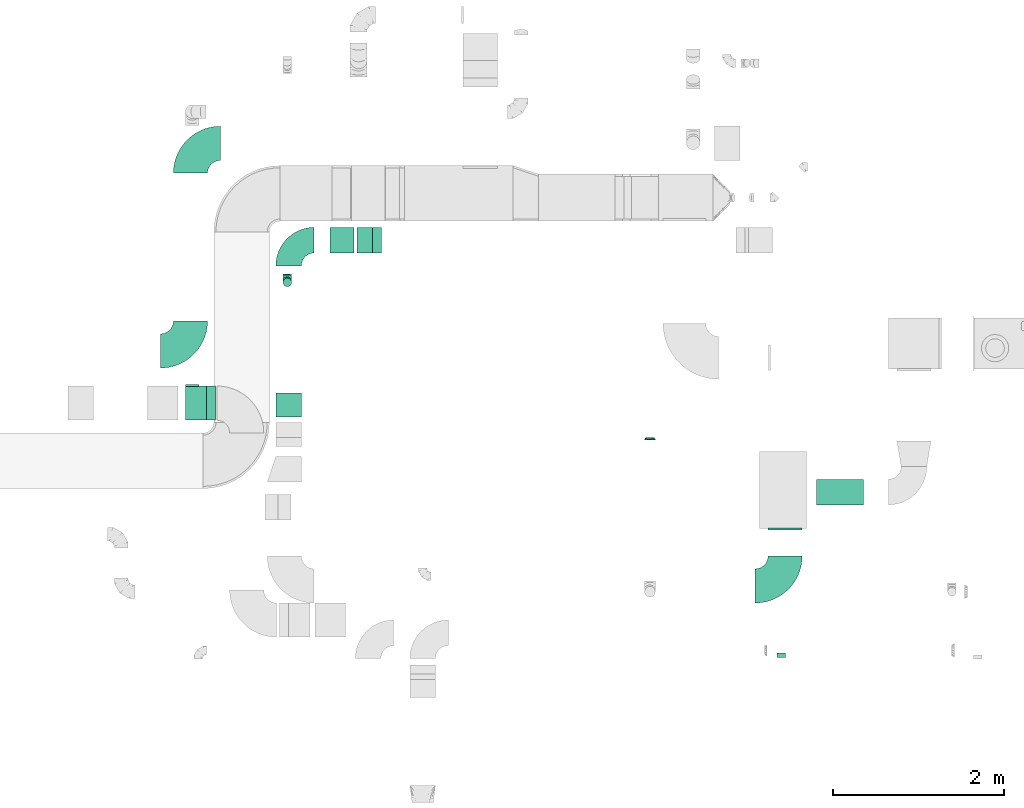
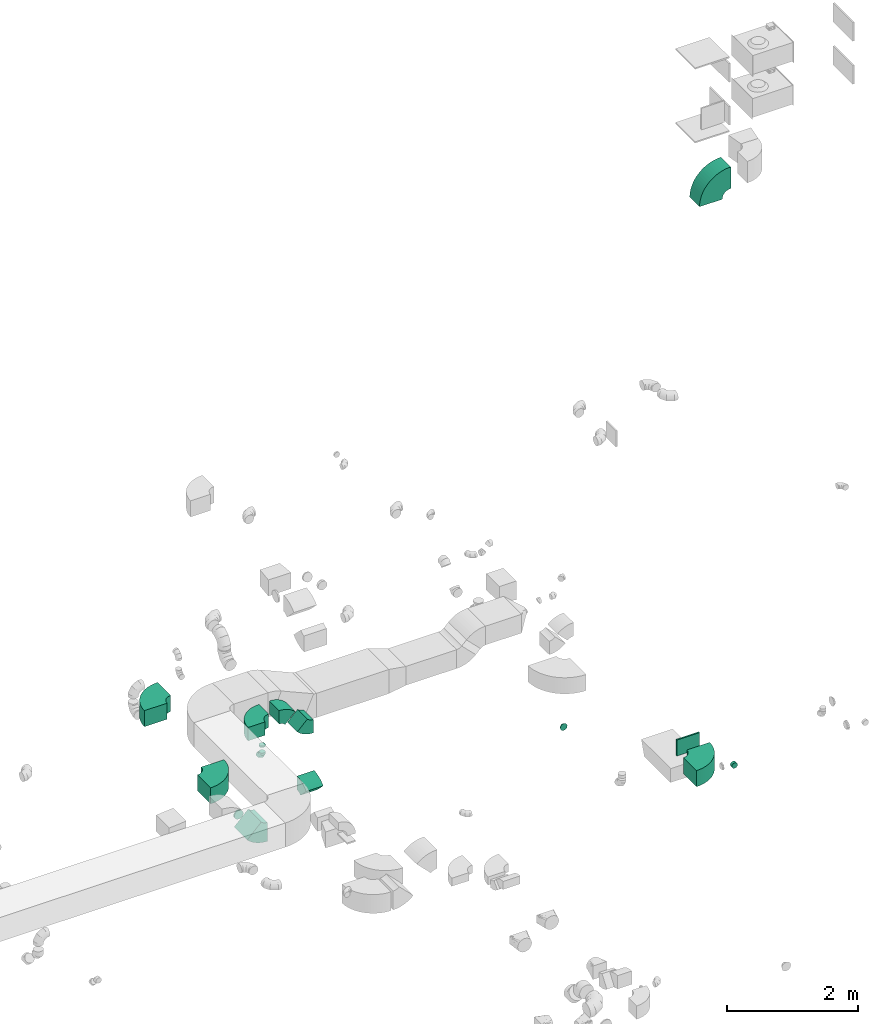
# One storey, part 12 of 44: 15 flow fittings.
"""IFC2X3 building model written with IfcOpenShell, lengths in millimetres."""

import ifcopenshell
import ifcopenshell.guid

model = None  # the IFC model being written
_history = None  # IfcOwnerHistory: only IFC2X3 demands one
_inside = {}  # id of a spatial element -> (the spatial element, [elements in it])
_under = {}  # id of a project, library or spatial element -> (it, [spatial elements below it])
_declared = {}  # id of a project -> (the project, [libraries it declares])
_typed = {}  # id of a type object -> (the type object, [elements of that type])
_made_of = {}  # id of a material, layer set ... -> (it, [elements and type objects made of it])


def new_model(schema):
    """Start an empty IFC model of exactly this schema.

    Asked for "IFC4X3", IfcOpenShell would pick the latest addendum, in which some entities
    have other attributes; the version numbers below select the first issue.
    IFC2X3 requires an IfcOwnerHistory on every rooted entity: one is made here for all.
    """
    global model, _history
    if schema == "IFC4X3":
        model = ifcopenshell.file(schema_version=(4, 3, 0, 0))
    else:
        model = ifcopenshell.file(schema=schema)
    _inside.clear()
    _under.clear()
    _declared.clear()
    _typed.clear()
    _made_of.clear()
    _history = None
    if model.schema == "IFC2X3":
        org = make("IfcOrganization", Name="unknown")
        user = make(
            "IfcPersonAndOrganization",
            ThePerson=make("IfcPerson", FamilyName="unknown"),
            TheOrganization=org,
        )
        app = make(
            "IfcApplication",
            ApplicationDeveloper=org,
            Version="unknown",
            ApplicationFullName="unknown",
            ApplicationIdentifier="unknown",
        )
        _history = make(
            "IfcOwnerHistory",
            OwningUser=user,
            OwningApplication=app,
            ChangeAction="ADDED",
            CreationDate=0,
        )
    return model


def make(cls, **values):
    """One entity of the class cls with the attributes given. An attribute that is None is left unset."""
    return model.create_entity(
        cls, **{name: value for name, value in values.items() if value is not None}
    )


def entity(cls, *values):
    """Any entity or typed value of the class cls, its attributes in the order of the schema. None: left unset."""
    e = model.create_entity(cls)
    for i, value in enumerate(values):
        if value is not None:
            e[i] = value
    return e


def rooted(cls, **values):
    """An entity with a GlobalId (a new one), such as an element, a storey or a relation."""
    return make(cls, GlobalId=ifcopenshell.guid.new(), OwnerHistory=_history, **values)


def si_unit(unit_type, name, prefix=None):
    """IfcSIUnit, for example si_unit("LENGTHUNIT", "METRE", prefix="MILLI")."""
    return make("IfcSIUnit", UnitType=unit_type, Prefix=prefix, Name=name)


def converted_unit(unit_type, name, factor, base, dimensions=None, offset=None):
    """IfcConversionBasedUnit, such as the inch: factor (a typed value) times the base unit."""
    return make(
        "IfcConversionBasedUnit"
        if offset is None
        else "IfcConversionBasedUnitWithOffset",
        ConversionOffset=offset,
        Dimensions=None
        if dimensions is None
        else entity("IfcDimensionalExponents", *dimensions),
        UnitType=unit_type,
        Name=name,
        ConversionFactor=make(
            "IfcMeasureWithUnit", ValueComponent=factor, UnitComponent=base
        ),
    )


def derived_unit(unit_type, elements):
    """IfcDerivedUnit: a product of units, each with its exponent."""
    return make(
        "IfcDerivedUnit",
        Elements=[
            make("IfcDerivedUnitElement", Unit=unit, Exponent=power)
            for unit, power in elements
        ],
        UnitType=unit_type,
    )


def assignment(units):
    """IfcUnitAssignment: the units of a project."""
    return None if units is None else make("IfcUnitAssignment", Units=units)


def point(xyz):
    """IfcCartesianPoint."""
    return None if xyz is None else make("IfcCartesianPoint", Coordinates=xyz)


def direction(xyz):
    """IfcDirection."""
    return None if xyz is None else make("IfcDirection", DirectionRatios=xyz)


def frame(location, z_axis=None, x_axis=None):
    """IfcAxis2Placement3D, a coordinate frame: its origin and axes. An axis left out is left unset."""
    return make(
        "IfcAxis2Placement3D",
        Location=point(location),
        Axis=direction(z_axis),
        RefDirection=direction(x_axis),
    )


def frame_2d(location, x_axis=None):
    """IfcAxis2Placement2D, a coordinate frame in the plane: its origin and x axis."""
    return make(
        "IfcAxis2Placement2D", Location=point(location), RefDirection=direction(x_axis)
    )


def origin():
    """The frame at (0, 0, 0) with its axes left unset."""
    return frame((0.0, 0.0, 0.0))


def origin_2d_with_axis():
    """The frame at (0, 0) in the plane with the x axis (1, 0) written out."""
    return frame_2d((0.0, 0.0), x_axis=(1.0, 0.0))


def place(relative_to, where):
    """IfcLocalPlacement: puts the frame where relative to a parent placement (None: the world)."""
    return make(
        "IfcLocalPlacement", PlacementRelTo=relative_to, RelativePlacement=where
    )


def context(
    kind, dimensions, precision=None, world=None, true_north=None, identifier=None
):
    """IfcGeometricRepresentationContext, for example the 3D "Model" context."""
    return make(
        "IfcGeometricRepresentationContext",
        ContextIdentifier=identifier,
        ContextType=kind,
        CoordinateSpaceDimension=dimensions,
        Precision=precision,
        WorldCoordinateSystem=world,
        TrueNorth=true_north,
    )


def subcontext(parent, identifier, kind, view, scale=None):
    """IfcGeometricRepresentationSubContext, for example "Body" below "Model"."""
    return make(
        "IfcGeometricRepresentationSubContext",
        ContextIdentifier=identifier,
        ContextType=kind,
        ParentContext=parent,
        TargetScale=scale,
        TargetView=view,
    )


def project(units=None, contexts=None):
    """IfcProject with its units and contexts."""
    return rooted(
        "IfcProject",
        Name="project",
        RepresentationContexts=contexts,
        UnitsInContext=assignment(units),
    )


def spatial(cls, under=None, at=None, **own):
    """A site, building, storey or space (cls), placed at a placement, below another one or the project."""
    s = rooted(cls, ObjectPlacement=at, **own)
    if under is not None:
        _under.setdefault(under.id(), (under, []))[1].append(s)
    return s


def polyline(points):
    """IfcPolyline through the points."""
    return make("IfcPolyline", Points=[point(p) for p in points])


def circle_curve(where, radius):
    """IfcCircle in the frame where."""
    return make("IfcCircle", Position=where, Radius=radius)


def parameter(value):
    """IfcParameterValue: where a trimmed curve begins or ends, as a parameter of its basis curve."""
    return model.create_entity("IfcParameterValue", value)


def trimmed(basis, trim1, trim2, sense, master):
    """IfcTrimmedCurve: the piece of a basis curve between two trims."""
    return make(
        "IfcTrimmedCurve",
        BasisCurve=basis,
        Trim1=trim1,
        Trim2=trim2,
        SenseAgreement=sense,
        MasterRepresentation=master,
    )


def segment(curve, same_sense, transition):
    """IfcCompositeCurveSegment."""
    return make(
        "IfcCompositeCurveSegment",
        Transition=transition,
        SameSense=same_sense,
        ParentCurve=curve,
    )


def composite_curve(segments, self_intersect=None):
    """IfcCompositeCurve: segments joined end to end."""
    return make("IfcCompositeCurve", Segments=segments, SelfIntersect=self_intersect)


def profile(cls, at=None, kind="AREA", **sizes):
    """A parametric profile (cls). Its sizes go by their IFC names, for example OverallWidth=200.0."""
    return make(cls, ProfileType=kind, Position=at, **sizes)


def rectangle(**sizes):
    """IfcRectangleProfileDef."""
    return profile("IfcRectangleProfileDef", **sizes)


def outline(outer, holes=None, kind="AREA"):
    """IfcArbitraryClosedProfileDef: a profile drawn as a closed curve; with holes, ...WithVoids."""
    if holes is None:
        return make("IfcArbitraryClosedProfileDef", ProfileType=kind, OuterCurve=outer)
    return make(
        "IfcArbitraryProfileDefWithVoids",
        ProfileType=kind,
        OuterCurve=outer,
        InnerCurves=holes,
    )


def extrude(swept, where, along, depth):
    """IfcExtrudedAreaSolid: the profile swept, set in the frame where, extruded along a direction by depth."""
    return make(
        "IfcExtrudedAreaSolid",
        SweptArea=swept,
        Position=where,
        ExtrudedDirection=direction(along),
        Depth=depth,
    )


def faces_of(points, faces, orient=None, outer=None):
    """IfcFace entities. A face is a list of loops; a loop is a list of indices into points, from 0.

    orient and outer hold one flag for each loop. By default every Orientation is true, the
    first loop of a face is its IfcFaceOuterBound and the others are IfcFaceBound.
    """
    made = []
    for i, loops in enumerate(faces):
        bounds = []
        for j, loop in enumerate(loops):
            is_outer = j == 0 if outer is None else outer[i][j]
            bounds.append(
                make(
                    "IfcFaceOuterBound" if is_outer else "IfcFaceBound",
                    Bound=make("IfcPolyLoop", Polygon=[points[k] for k in loop]),
                    Orientation=True if orient is None else orient[i][j],
                )
            )
        made.append(make("IfcFace", Bounds=bounds))
    return made


def faceted_brep(points, faces, orient=None, outer=None, voids=None):
    """IfcFacetedBrep: a solid bounded by flat faces; with voids (closed shells), ...WithVoids."""
    shared = [point(p) for p in points]
    hull = make("IfcClosedShell", CfsFaces=faces_of(shared, faces, orient, outer))
    if voids is None:
        return make("IfcFacetedBrep", Outer=hull)
    return make(
        "IfcFacetedBrepWithVoids",
        Outer=hull,
        Voids=[
            make(cls, CfsFaces=faces_of(shared, fs, o, b)) for cls, fs, o, b in voids
        ],
    )


def shape(context_of_items, identifier, shape_type, items):
    """IfcShapeRepresentation: the items that make up one representation, for example the "Body"."""
    return make(
        "IfcShapeRepresentation",
        ContextOfItems=context_of_items,
        RepresentationIdentifier=identifier,
        RepresentationType=shape_type,
        Items=items,
    )


def source(mapping_origin, context_of_items, identifier, shape_type, items):
    """IfcRepresentationMap: a shape defined once, which mapped items show again and again."""
    return make(
        "IfcRepresentationMap",
        MappingOrigin=mapping_origin,
        MappedRepresentation=shape(context_of_items, identifier, shape_type, items),
    )


def transform(
    local_origin,
    x_axis=None,
    y_axis=None,
    z_axis=None,
    scale=None,
    scale2=None,
    scale3=None,
    uniform=True,
):
    """IfcCartesianTransformationOperator3D, or its non-uniform kind. x_axis, y_axis, z_axis: its Axis1, 2, 3."""
    if uniform:
        return make(
            "IfcCartesianTransformationOperator3D",
            Axis1=direction(x_axis),
            Axis2=direction(y_axis),
            LocalOrigin=point(local_origin),
            Scale=scale,
            Axis3=direction(z_axis),
        )
    return make(
        "IfcCartesianTransformationOperator3DnonUniform",
        Axis1=direction(x_axis),
        Axis2=direction(y_axis),
        LocalOrigin=point(local_origin),
        Scale=scale,
        Axis3=direction(z_axis),
        Scale2=scale2,
        Scale3=scale3,
    )


def mapped(mapping_source, mapping_target):
    """IfcMappedItem: shows the shape of a source again, moved by a transform."""
    return make(
        "IfcMappedItem", MappingSource=mapping_source, MappingTarget=mapping_target
    )


def material(Name=None, Category=None):
    """IfcMaterial."""
    return make("IfcMaterial", Name=Name, Category=Category)


def made_of(thing, what):
    """Note that an element or type object is made of a material, layer set ...; save() writes the relation."""
    if what is not None:
        _made_of.setdefault(what.id(), (what, []))[1].append(thing)
    return thing


def type_object(cls, material=None, **own):
    """A type object (cls), such as IfcWallType, which elements share."""
    return made_of(rooted(cls, **own), material)


def type_shapes(of_type, sources):
    """Give a type object the sources (RepresentationMaps) that its elements show as mapped items."""
    of_type.RepresentationMaps = sources


def element(
    cls,
    number,
    at=None,
    inside=None,
    cuts=None,
    type_object=None,
    material=None,
    context=None,
    identifier="Body",
    shape_type=None,
    held_by="IfcProductDefinitionShape",
    body=None,
    shapes=None,
    **own,
):
    """One element of the class cls, such as IfcWall. Its Tag is "e" and its number.

    at: its placement. inside: the storey or other place that contains it. cuts: it is an
    opening in that element (IfcRelVoidsElement). A single representation is given by context,
    identifier, shape_type and body (its items); several are given by shapes. held_by: the class
    of the entity that holds the representations. save() writes the other relations.
    """
    e = rooted(cls, Tag="e%d" % number, ObjectPlacement=at, **own)
    if body is not None:
        shapes = [shape(context, identifier, shape_type, body)]
    if shapes is not None:
        e.Representation = make(held_by, Representations=shapes)
    if inside is not None:
        _inside.setdefault(inside.id(), (inside, []))[1].append(e)
    if cuts is not None:
        rooted(
            "IfcRelVoidsElement", RelatingBuildingElement=cuts, RelatedOpeningElement=e
        )
    if type_object is not None:
        _typed.setdefault(type_object.id(), (type_object, []))[1].append(e)
    return made_of(e, material)


def aggregate(whole, parts):
    """IfcRelAggregates: a whole, such as a stair, and the parts it consists of."""
    return rooted("IfcRelAggregates", RelatingObject=whole, RelatedObjects=parts)


def save(model, path):
    """Write the relations noted so far, then the file.

    IfcRelAggregates (storeys below a building ...), IfcRelContainedInSpatialStructure (elements
    in a storey), IfcRelDefinesByType, IfcRelAssociatesMaterial and IfcRelDeclares: one each for
    every whole, place, type object, material and project.
    """
    for whole, parts in _under.values():
        aggregate(whole, parts)
    for where, things in _inside.values():
        rooted(
            "IfcRelContainedInSpatialStructure",
            RelatedElements=things,
            RelatingStructure=where,
        )
    for kind, things in _typed.values():
        rooted("IfcRelDefinesByType", RelatedObjects=things, RelatingType=kind)
    for what, things in _made_of.values():
        rooted("IfcRelAssociatesMaterial", RelatedObjects=things, RelatingMaterial=what)
    for by, libraries in _declared.values():
        rooted("IfcRelDeclares", RelatingContext=by, RelatedDefinitions=libraries)
    model.write(path)


model = new_model("IFC2X3")

# Units and contexts
model_context = context("Model", 3, precision=0.01, world=origin(), true_north=direction((6.12303176911189e-17, 1.0)))
body_context = subcontext(model_context, "Body", "Model", "MODEL_VIEW")
ifc_project = project(units=[si_unit("LENGTHUNIT", "METRE", prefix="MILLI"), si_unit("AREAUNIT", "SQUARE_METRE"), si_unit("VOLUMEUNIT", "CUBIC_METRE"), converted_unit("PLANEANGLEUNIT", "DEGREE", entity("IfcRatioMeasure", 0.0174532925199433), si_unit("PLANEANGLEUNIT", "RADIAN"), dimensions=[0, 0, 0, 0, 0, 0, 0]), si_unit("MASSUNIT", "GRAM", prefix="KILO"), derived_unit("MASSDENSITYUNIT", [(si_unit("MASSUNIT", "GRAM", prefix="KILO"), 1), (si_unit("LENGTHUNIT", "METRE"), -3)]), derived_unit("MOMENTOFINERTIAUNIT", [(si_unit("LENGTHUNIT", "METRE"), 4)]), si_unit("TIMEUNIT", "SECOND"), si_unit("FREQUENCYUNIT", "HERTZ"), si_unit("THERMODYNAMICTEMPERATUREUNIT", "DEGREE_CELSIUS"), derived_unit("THERMALTRANSMITTANCEUNIT", [(si_unit("MASSUNIT", "GRAM", prefix="KILO"), 1), (si_unit("THERMODYNAMICTEMPERATUREUNIT", "KELVIN"), -1), (si_unit("TIMEUNIT", "SECOND"), -3)]), derived_unit("VOLUMETRICFLOWRATEUNIT", [(si_unit("LENGTHUNIT", "METRE"), 3), (si_unit("TIMEUNIT", "SECOND"), -1)]), derived_unit("MASSFLOWRATEUNIT", [(si_unit("MASSUNIT", "GRAM", prefix="KILO"), 1), (si_unit("TIMEUNIT", "SECOND"), -1)]), derived_unit("ROTATIONALFREQUENCYUNIT", [(si_unit("TIMEUNIT", "SECOND"), -1)]), si_unit("ELECTRICCURRENTUNIT", "AMPERE"), si_unit("ELECTRICVOLTAGEUNIT", "VOLT"), si_unit("POWERUNIT", "WATT"), si_unit("FORCEUNIT", "NEWTON", prefix="KILO"), si_unit("ILLUMINANCEUNIT", "LUX"), si_unit("LUMINOUSFLUXUNIT", "LUMEN"), si_unit("LUMINOUSINTENSITYUNIT", "CANDELA"), derived_unit("USERDEFINED", [(si_unit("MASSUNIT", "GRAM", prefix="KILO"), -1), (si_unit("LENGTHUNIT", "METRE"), -2), (si_unit("TIMEUNIT", "SECOND"), 3), (si_unit("LUMINOUSFLUXUNIT", "LUMEN"), 1)]), derived_unit("LINEARVELOCITYUNIT", [(si_unit("LENGTHUNIT", "METRE"), 1), (si_unit("TIMEUNIT", "SECOND"), -1)]), si_unit("PRESSUREUNIT", "PASCAL"), derived_unit("USERDEFINED", [(si_unit("LENGTHUNIT", "METRE"), -2), (si_unit("MASSUNIT", "GRAM", prefix="KILO"), 1), (si_unit("TIMEUNIT", "SECOND"), -2)]), derived_unit("LINEARFORCEUNIT", [(si_unit("MASSUNIT", "GRAM", prefix="KILO"), 1), (si_unit("LENGTHUNIT", "METRE"), 1), (si_unit("TIMEUNIT", "SECOND"), -2), (si_unit("LENGTHUNIT", "METRE"), -1)]), derived_unit("PLANARFORCEUNIT", [(si_unit("MASSUNIT", "GRAM", prefix="KILO"), 1), (si_unit("LENGTHUNIT", "METRE"), 1), (si_unit("TIMEUNIT", "SECOND"), -2), (si_unit("LENGTHUNIT", "METRE"), -2)])], contexts=[model_context])

# Site, building, storey
site_placement = place(None, origin())
site = spatial("IfcSite", under=ifc_project, at=site_placement, CompositionType="ELEMENT")
building_placement = place(site_placement, origin())
building = spatial("IfcBuilding", under=site, at=building_placement, CompositionType="ELEMENT")
storey_placement = place(building_placement, frame((0.0, 0.0, 15900.0)))
storey = spatial("IfcBuildingStorey", under=building, at=storey_placement, CompositionType="ELEMENT", Elevation=15900.0)

# Flow fittings
ifc_material = material()
duct_fitting_type_1 = type_object("IfcDuctFittingType", PredefinedType="NOTDEFINED", material=ifc_material)
shared_shape_1 = source(origin(), body_context, "Body", "SweptSolid", [
    extrude(rectangle(XDim=26.0960000000546, YDim=300.0, at=origin_2d_with_axis()), frame((6.95, 0.0, -200.0)), (0.0, 0.0, 1.0), 400.0),
])
type_shapes(duct_fitting_type_1, [shared_shape_1])
flow_fitting_1_placement = place(storey_placement, frame((24365.55, 10799.36, 2850.0), z_axis=(-1.0, 0.0, 0.0), x_axis=(0.0, -1.0, 0.0)))
element("IfcFlowFitting", 1, at=flow_fitting_1_placement, inside=storey, type_object=duct_fitting_type_1, material=ifc_material, context=body_context, shape_type="MappedRepresentation", body=[
    mapped(shared_shape_1, transform((0.0, 0.0, 0.0), scale=1.0)),
])
duct_fitting_type_2 = type_object("IfcDuctFittingType", PredefinedType="NOTDEFINED", material=ifc_material)
shared_shape_2 = source(origin(), body_context, "Body", "Brep", [
    faceted_brep([(-100.0, 0.0, -50.0), (-100.0, -12.94, -48.3), (-100.0, -25.0, -43.3), (-100.0, -35.36, -35.36), (-100.0, -43.3, -25.0), (-100.0, -48.3, -12.94), (-100.0, -50.0, 0.0), (-100.0, -48.3, 12.94), (-100.0, -43.3, 25.0), (-100.0, -35.36, 35.36), (-100.0, -25.0, 43.3), (-100.0, -12.94, 48.3), (-100.0, 0.0, 50.0), (-100.0, 12.94, 48.3), (-100.0, 25.0, 43.3), (-100.0, 35.36, 35.36), (-100.0, 43.3, 25.0), (-100.0, 48.3, 12.94), (-100.0, 50.0, 0.0), (-100.0, 48.3, -12.94), (-100.0, 43.3, -25.0), (-100.0, 35.36, -35.36), (-100.0, 25.0, -43.3), (-100.0, 12.94, -48.3), (-76.67, 12.94, 48.3), (-79.9, 25.0, 43.3), (-73.21, 0.0, 50.0), (-82.68, 35.36, 35.36), (-86.15, 48.3, 12.94), (-86.6, 50.0, 0.0), (-84.81, 43.3, 25.0), (-84.81, 43.3, -25.0), (-82.68, 35.36, -35.36), (-86.15, 48.3, -12.94), (-76.67, 12.94, -48.3), (-73.21, 0.0, -50.0), (-79.9, 25.0, -43.3), (-69.74, -12.94, -48.3), (-66.51, -25.0, -43.3), (-63.73, -35.36, -35.36), (-61.6, -43.3, -25.0), (-60.26, -48.3, -12.94), (-59.81, -50.0, 0.0), (-60.26, -48.3, 12.94), (-61.6, -43.3, 25.0), (-63.73, -35.36, 35.36), (-66.51, -25.0, 43.3), (-69.74, -12.94, 48.3), (-36.27, 36.27, 48.3), (-45.1, 45.1, 43.3), (-26.79, 26.79, 50.0), (-52.68, 52.68, 35.36), (-58.49, 58.49, 25.0), (-62.15, 62.15, 12.94), (-63.4, 63.4, 0.0), (-62.15, 62.15, -12.94), (-58.49, 58.49, -25.0), (-52.68, 52.68, -35.36), (-36.27, 36.27, -48.3), (-26.79, 26.79, -50.0), (-45.1, 45.1, -43.3), (-17.32, 17.32, -48.3), (-8.49, 8.49, -43.3), (-0.91, 0.91, -35.36), (4.9, -4.9, -25.0), (8.56, -8.56, -12.94), (9.81, -9.81, 0.0), (8.56, -8.56, 12.94), (4.9, -4.9, 25.0), (-0.91, 0.91, 35.36), (-8.49, 8.49, 43.3), (-17.32, 17.32, 48.3), (-12.94, 76.67, 48.3), (-25.0, 79.9, 43.3), (0.0, 73.21, 50.0), (-35.36, 82.68, 35.36), (-43.3, 84.81, 25.0), (-48.3, 86.15, 12.94), (-50.0, 86.6, 0.0), (-48.3, 86.15, -12.94), (-43.3, 84.81, -25.0), (-35.36, 82.68, -35.36), (-12.94, 76.67, -48.3), (0.0, 73.21, -50.0), (-25.0, 79.9, -43.3), (12.94, 69.74, -48.3), (25.0, 66.51, -43.3), (35.36, 63.73, -35.36), (43.3, 61.6, -25.0), (48.3, 60.26, -12.94), (50.0, 59.81, 0.0), (48.3, 60.26, 12.94), (43.3, 61.6, 25.0), (35.36, 63.73, 35.36), (25.0, 66.51, 43.3), (12.94, 69.74, 48.3), (-12.94, 100.0, -48.3), (-25.0, 100.0, -43.3), (-35.36, 100.0, -35.36), (-43.3, 100.0, -25.0), (-48.3, 100.0, -12.94), (-50.0, 100.0, 0.0), (-48.3, 100.0, 12.94), (-43.3, 100.0, 25.0), (-35.36, 100.0, 35.36), (-25.0, 100.0, 43.3), (-12.94, 100.0, 48.3), (0.0, 100.0, 50.0), (12.94, 100.0, 48.3), (25.0, 100.0, 43.3), (35.36, 100.0, 35.36), (43.3, 100.0, 25.0), (48.3, 100.0, 12.94), (50.0, 100.0, 0.0), (48.3, 100.0, -12.94), (43.3, 100.0, -25.0), (35.36, 100.0, -35.36), (25.0, 100.0, -43.3), (12.94, 100.0, -48.3), (0.0, 100.0, -50.0)], [[[0, 1, 2, 3, 4, 5, 6, 7, 8, 9, 10, 11, 12, 13, 14, 15, 16, 17, 18, 19, 20, 21, 22, 23]], [[24, 25, 14, 13]], [[26, 24, 13, 12]], [[14, 25, 27, 15]], [[28, 29, 18, 17]], [[30, 28, 17, 16]], [[15, 27, 30, 16]], [[20, 31, 32, 21]], [[33, 31, 20, 19]], [[18, 29, 33, 19]], [[34, 35, 0, 23]], [[36, 34, 23, 22]], [[32, 36, 22, 21]], [[2, 1, 37, 38]], [[3, 2, 38, 39]], [[0, 35, 37, 1]], [[5, 4, 40, 41]], [[6, 5, 41, 42]], [[3, 39, 40, 4]], [[6, 42, 43, 7]], [[7, 43, 44, 8]], [[8, 44, 45, 9]], [[10, 46, 47, 11]], [[11, 47, 26, 12]], [[10, 9, 45, 46]], [[48, 49, 25, 24]], [[50, 48, 24, 26]], [[27, 25, 49, 51]], [[52, 53, 28, 30]], [[51, 52, 30, 27]], [[29, 28, 53, 54]], [[55, 56, 31, 33]], [[54, 55, 33, 29]], [[57, 32, 31, 56]], [[58, 59, 35, 34]], [[60, 58, 34, 36]], [[57, 60, 36, 32]], [[37, 35, 59, 61]], [[38, 37, 61, 62]], [[39, 38, 62, 63]], [[41, 40, 64, 65]], [[42, 41, 65, 66]], [[63, 64, 40, 39]], [[43, 42, 66, 67]], [[44, 43, 67, 68]], [[68, 69, 45, 44]], [[46, 45, 69, 70]], [[47, 46, 70, 71]], [[26, 47, 71, 50]], [[72, 73, 49, 48]], [[74, 72, 48, 50]], [[51, 49, 73, 75]], [[76, 77, 53, 52]], [[75, 76, 52, 51]], [[54, 53, 77, 78]], [[79, 80, 56, 55]], [[78, 79, 55, 54]], [[81, 57, 56, 80]], [[82, 83, 59, 58]], [[84, 82, 58, 60]], [[81, 84, 60, 57]], [[61, 59, 83, 85]], [[62, 61, 85, 86]], [[63, 62, 86, 87]], [[65, 64, 88, 89]], [[66, 65, 89, 90]], [[87, 88, 64, 63]], [[67, 66, 90, 91]], [[68, 67, 91, 92]], [[92, 93, 69, 68]], [[70, 69, 93, 94]], [[71, 70, 94, 95]], [[50, 71, 95, 74]], [[96, 97, 98, 99, 100, 101, 102, 103, 104, 105, 106, 107, 108, 109, 110, 111, 112, 113, 114, 115, 116, 117, 118, 119]], [[72, 74, 107, 106]], [[73, 72, 106, 105]], [[75, 73, 105, 104]], [[77, 76, 103, 102]], [[78, 77, 102, 101]], [[75, 104, 103, 76]], [[78, 101, 100, 79]], [[79, 100, 99, 80]], [[80, 99, 98, 81]], [[96, 119, 83, 82]], [[97, 96, 82, 84]], [[84, 81, 98, 97]], [[83, 119, 118, 85]], [[85, 118, 117, 86]], [[86, 117, 116, 87]], [[88, 115, 114, 89]], [[89, 114, 113, 90]], [[87, 116, 115, 88]], [[91, 90, 113, 112]], [[92, 91, 112, 111]], [[93, 92, 111, 110]], [[95, 94, 109, 108]], [[74, 95, 108, 107]], [[110, 109, 94, 93]]]),
])
type_shapes(duct_fitting_type_2, [shared_shape_2])
flow_fitting_2_placement = place(storey_placement, frame((18534.53, 13681.21, 2900.0), z_axis=(-1.0, 0.0, 0.0), x_axis=(0.0, -1.0, 0.0)))
element("IfcFlowFitting", 2, at=flow_fitting_2_placement, inside=storey, type_object=duct_fitting_type_2, material=ifc_material, context=body_context, shape_type="MappedRepresentation", body=[
    mapped(shared_shape_2, transform((0.0, 0.0, 0.0), scale=1.0)),
])
duct_fitting_type_3 = type_object("IfcDuctFittingType", PredefinedType="NOTDEFINED", material=ifc_material)
shared_shape_3 = source(origin(), body_context, "Body", "Brep", [
    faceted_brep([(20.0, 0.0, -80.0), (20.0, 20.71, -77.27), (20.0, 40.0, -69.28), (20.0, 56.57, -56.57), (20.0, 69.28, -40.0), (20.0, 77.27, -20.71), (20.0, 80.0, 0.0), (20.0, 77.27, 20.71), (20.0, 69.28, 40.0), (20.0, 56.57, 56.57), (20.0, 40.0, 69.28), (20.0, 20.71, 77.27), (20.0, 0.0, 80.0), (20.0, -20.71, 77.27), (20.0, -40.0, 69.28), (20.0, -56.57, 56.57), (20.0, -69.28, 40.0), (20.0, -77.27, 20.71), (20.0, -80.0, 0.0), (20.0, -77.27, -20.71), (20.0, -69.28, -40.0), (20.0, -56.57, -56.57), (20.0, -40.0, -69.28), (20.0, -20.71, -77.27), (0.0, 0.0, 80.0), (-6.1, 0.0, 80.0), (-6.1, -20.71, 77.27), (0.0, -20.71, 77.27), (-6.1, -40.0, 69.28), (0.0, -40.0, 69.28), (0.0, -56.57, 56.57), (-6.1, -56.57, 56.57), (0.0, -69.28, 40.0), (-6.1, -69.28, 40.0), (-6.1, -77.27, 20.71), (0.0, -77.27, 20.71), (-6.1, -80.0, 0.0), (0.0, -80.0, 0.0), (-6.1, -77.27, -20.71), (0.0, -77.27, -20.71), (-6.1, -69.28, -40.0), (0.0, -69.28, -40.0), (0.0, -56.57, -56.57), (-6.1, -56.57, -56.57), (0.0, -40.0, -69.28), (-6.1, -40.0, -69.28), (-6.1, -20.71, -77.27), (0.0, -20.71, -77.27), (-6.1, 0.0, -80.0), (0.0, 0.0, -80.0), (-6.1, 20.71, -77.27), (0.0, 20.71, -77.27), (-6.1, 40.0, -69.28), (0.0, 40.0, -69.28), (0.0, 56.57, -56.57), (-6.1, 56.57, -56.57), (0.0, 69.28, -40.0), (-6.1, 69.28, -40.0), (-6.1, 77.27, -20.71), (0.0, 77.27, -20.71), (-6.1, 80.0, 0.0), (0.0, 80.0, 0.0), (-6.1, 77.27, 20.71), (0.0, 77.27, 20.71), (-6.1, 69.28, 40.0), (0.0, 69.28, 40.0), (0.0, 56.57, 56.57), (-6.1, 56.57, 56.57), (0.0, 40.0, 69.28), (-6.1, 40.0, 69.28), (-6.1, 20.71, 77.27), (0.0, 20.71, 77.27)], [[[0, 1, 2, 3, 4, 5, 6, 7, 8, 9, 10, 11, 12, 13, 14, 15, 16, 17, 18, 19, 20, 21, 22, 23]], [[13, 12, 24, 25, 26, 27]], [[14, 13, 27, 26, 28, 29]], [[30, 15, 14, 29, 28, 31]], [[17, 16, 32, 33, 34, 35]], [[18, 17, 35, 34, 36, 37]], [[32, 16, 15, 30, 31, 33]], [[19, 18, 37, 36, 38, 39]], [[20, 19, 39, 38, 40, 41]], [[42, 21, 20, 41, 40, 43]], [[23, 22, 44, 45, 46, 47]], [[0, 23, 47, 46, 48, 49]], [[44, 22, 21, 42, 43, 45]], [[1, 0, 49, 48, 50, 51]], [[2, 1, 51, 50, 52, 53]], [[54, 3, 2, 53, 52, 55]], [[5, 4, 56, 57, 58, 59]], [[6, 5, 59, 58, 60, 61]], [[56, 4, 3, 54, 55, 57]], [[7, 6, 61, 60, 62, 63]], [[8, 7, 63, 62, 64, 65]], [[66, 9, 8, 65, 64, 67]], [[11, 10, 68, 69, 70, 71]], [[12, 11, 71, 70, 25, 24]], [[68, 10, 9, 66, 67, 69]], [[46, 45, 43, 40, 38, 36, 34, 33, 31, 28, 26, 25, 70, 69, 67, 64, 62, 60, 58, 57, 55, 52, 50, 48]]]),
])
type_shapes(duct_fitting_type_3, [shared_shape_3])
flow_fitting_3_placement = place(storey_placement, frame((17420.49, 12467.41, 2950.0), z_axis=(0.0, 0.0, -1.0), x_axis=(0.0, 1.0, 0.0)))
element("IfcFlowFitting", 3, at=flow_fitting_3_placement, inside=storey, type_object=duct_fitting_type_3, material=ifc_material, context=body_context, shape_type="MappedRepresentation", body=[
    mapped(shared_shape_3, transform((0.0, 0.0, 0.0), scale=1.0)),
])
duct_fitting_type_4 = type_object("IfcDuctFittingType", PredefinedType="NOTDEFINED", material=ifc_material)
shared_shape_4 = source(origin(), body_context, "Body", "Brep", [
    faceted_brep([(25.0, -46.19, 19.13), (25.0, -48.1, 9.57), (25.0, -50.0, 0.0), (25.0, -48.1, -9.57), (25.0, -46.19, -19.13), (25.0, -40.77, -27.24), (25.0, -35.36, -35.36), (25.0, -27.24, -40.77), (25.0, -19.13, -46.19), (25.0, -9.57, -48.1), (25.0, 0.0, -50.0), (25.0, 9.57, -48.1), (25.0, 19.13, -46.19), (25.0, 27.24, -40.77), (25.0, 35.36, -35.36), (25.0, 40.77, -27.24), (25.0, 46.19, -19.13), (25.0, 48.1, -9.57), (25.0, 50.0, 0.0), (25.0, 48.1, 9.57), (25.0, 46.19, 19.13), (25.0, 40.77, 27.24), (25.0, 35.36, 35.36), (25.0, 27.24, 40.77), (25.0, 19.13, 46.19), (25.0, 9.57, 48.1), (25.0, 0.0, 50.0), (25.0, -9.57, 48.1), (25.0, -19.13, 46.19), (25.0, -27.24, 40.77), (25.0, -35.36, 35.36), (25.0, -40.77, 27.24), (0.0, -62.5, 0.0), (0.0, -60.02, 12.45), (0.0, -57.74, 23.92), (0.0, -50.97, 34.06), (0.0, -44.19, 44.19), (0.0, -34.06, 50.97), (0.0, -23.92, 57.74), (0.0, -12.45, 60.02), (0.0, 0.0, 62.5), (0.0, 12.45, 60.02), (0.0, 23.92, 57.74), (0.0, 34.06, 50.97), (0.0, 44.19, 44.19), (0.0, 50.97, 34.06), (0.0, 57.74, 23.92), (0.0, 60.02, 12.45), (0.0, 62.5, 0.0), (0.0, 60.02, -12.45), (0.0, 57.74, -23.92), (0.0, 50.97, -34.06), (0.0, 44.19, -44.19), (0.0, 34.06, -50.97), (0.0, 23.92, -57.74), (0.0, 12.45, -60.02), (0.0, 0.0, -62.5), (0.0, -12.45, -60.02), (0.0, -23.92, -57.74), (0.0, -34.06, -50.97), (0.0, -44.19, -44.19), (0.0, -50.97, -34.06), (0.0, -57.74, -23.92), (0.0, -60.02, -12.45)], [[[0, 1, 2, 3, 4, 5, 6, 7, 8, 9, 10, 11, 12, 13, 14, 15, 16, 17, 18, 19, 20, 21, 22, 23, 24, 25, 26, 27, 28, 29, 30, 31]], [[32, 33, 34, 35, 36, 37, 38, 39, 40, 41, 42, 43, 44, 45, 46, 47, 48, 49, 50, 51, 52, 53, 54, 55, 56, 57, 58, 59, 60, 61, 62, 63]], [[24, 42, 41, 40, 26, 25]], [[22, 44, 43, 42, 24, 23]], [[48, 47, 46, 20, 19, 18]], [[44, 22, 21, 20, 46, 45]], [[0, 34, 33, 32, 2, 1]], [[30, 36, 35, 34, 0, 31]], [[40, 39, 38, 28, 27, 26]], [[36, 30, 29, 28, 38, 37]], [[8, 58, 57, 56, 10, 9]], [[6, 60, 59, 58, 8, 7]], [[32, 63, 62, 4, 3, 2]], [[60, 6, 5, 4, 62, 61]], [[16, 50, 49, 48, 18, 17]], [[14, 52, 51, 50, 16, 15]], [[56, 55, 54, 12, 11, 10]], [[52, 14, 13, 12, 54, 53]]]),
])
type_shapes(duct_fitting_type_4, [shared_shape_4])
flow_fitting_4_placement = place(storey_placement, frame((22782.58, 11837.12, 3085.0), z_axis=(0.0, 0.0, 1.0), x_axis=(0.0, 1.0, 0.0)))
element("IfcFlowFitting", 4, at=flow_fitting_4_placement, inside=storey, type_object=duct_fitting_type_4, material=ifc_material, context=body_context, shape_type="MappedRepresentation", body=[
    mapped(shared_shape_4, transform((0.0, 0.0, 0.0), scale=1.0)),
])
duct_fitting_type_5 = type_object("IfcDuctFittingType", PredefinedType="NOTDEFINED", material=ifc_material)
shared_shape_5 = source(origin(), body_context, "Body", "Brep", [
    faceted_brep([(20.0, 0.0, -50.0), (20.0, 12.94, -48.3), (20.0, 25.0, -43.3), (20.0, 35.36, -35.36), (20.0, 43.3, -25.0), (20.0, 48.3, -12.94), (20.0, 50.0, 0.0), (20.0, 48.3, 12.94), (20.0, 43.3, 25.0), (20.0, 35.36, 35.36), (20.0, 25.0, 43.3), (20.0, 12.94, 48.3), (20.0, 0.0, 50.0), (20.0, -12.94, 48.3), (20.0, -25.0, 43.3), (20.0, -35.36, 35.36), (20.0, -43.3, 25.0), (20.0, -48.3, 12.94), (20.0, -50.0, 0.0), (20.0, -48.3, -12.94), (20.0, -43.3, -25.0), (20.0, -35.36, -35.36), (20.0, -25.0, -43.3), (20.0, -12.94, -48.3), (0.0, 0.0, 50.0), (-6.1, 0.0, 50.0), (-6.1, -12.94, 48.3), (0.0, -12.94, 48.3), (-6.1, -25.0, 43.3), (0.0, -25.0, 43.3), (0.0, -35.36, 35.36), (-6.1, -35.36, 35.36), (0.0, -43.3, 25.0), (-6.1, -43.3, 25.0), (-6.1, -48.3, 12.94), (0.0, -48.3, 12.94), (-6.1, -50.0, 0.0), (0.0, -50.0, 0.0), (-6.1, -48.3, -12.94), (0.0, -48.3, -12.94), (-6.1, -43.3, -25.0), (0.0, -43.3, -25.0), (0.0, -35.36, -35.36), (-6.1, -35.36, -35.36), (0.0, -25.0, -43.3), (-6.1, -25.0, -43.3), (-6.1, -12.94, -48.3), (0.0, -12.94, -48.3), (-6.1, 0.0, -50.0), (0.0, 0.0, -50.0), (-6.1, 12.94, -48.3), (0.0, 12.94, -48.3), (-6.1, 25.0, -43.3), (0.0, 25.0, -43.3), (0.0, 35.36, -35.36), (-6.1, 35.36, -35.36), (0.0, 43.3, -25.0), (-6.1, 43.3, -25.0), (-6.1, 48.3, -12.94), (0.0, 48.3, -12.94), (-6.1, 50.0, 0.0), (0.0, 50.0, 0.0), (-6.1, 48.3, 12.94), (0.0, 48.3, 12.94), (-6.1, 43.3, 25.0), (0.0, 43.3, 25.0), (0.0, 35.36, 35.36), (-6.1, 35.36, 35.36), (0.0, 25.0, 43.3), (-6.1, 25.0, 43.3), (-6.1, 12.94, 48.3), (0.0, 12.94, 48.3)], [[[0, 1, 2, 3, 4, 5, 6, 7, 8, 9, 10, 11, 12, 13, 14, 15, 16, 17, 18, 19, 20, 21, 22, 23]], [[13, 12, 24, 25, 26, 27]], [[14, 13, 27, 26, 28, 29]], [[30, 15, 14, 29, 28, 31]], [[17, 16, 32, 33, 34, 35]], [[18, 17, 35, 34, 36, 37]], [[32, 16, 15, 30, 31, 33]], [[19, 18, 37, 36, 38, 39]], [[20, 19, 39, 38, 40, 41]], [[42, 21, 20, 41, 40, 43]], [[23, 22, 44, 45, 46, 47]], [[0, 23, 47, 46, 48, 49]], [[44, 22, 21, 42, 43, 45]], [[1, 0, 49, 48, 50, 51]], [[2, 1, 51, 50, 52, 53]], [[54, 3, 2, 53, 52, 55]], [[5, 4, 56, 57, 58, 59]], [[6, 5, 59, 58, 60, 61]], [[56, 4, 3, 54, 55, 57]], [[7, 6, 61, 60, 62, 63]], [[8, 7, 63, 62, 64, 65]], [[66, 9, 8, 65, 64, 67]], [[11, 10, 68, 69, 70, 71]], [[12, 11, 71, 70, 25, 24]], [[68, 10, 9, 66, 67, 69]], [[46, 45, 43, 40, 38, 36, 34, 33, 31, 28, 26, 25, 70, 69, 67, 64, 62, 60, 58, 57, 55, 52, 50, 48]]]),
])
type_shapes(duct_fitting_type_5, [shared_shape_5])
flow_fitting_5_placement = place(storey_placement, frame((18534.53, 13681.21, 3125.0), z_axis=(0.0, 1.0, 0.0), x_axis=(0.0, 0.0, -1.0)))
element("IfcFlowFitting", 5, at=flow_fitting_5_placement, inside=storey, type_object=duct_fitting_type_5, material=ifc_material, context=body_context, shape_type="MappedRepresentation", body=[
    mapped(shared_shape_5, transform((0.0, 0.0, 0.0), scale=1.0)),
])
duct_fitting_type_6 = type_object("IfcDuctFittingType", PredefinedType="NOTDEFINED", material=ifc_material)
shared_shape_6 = source(origin(), body_context, "Body", "Brep", [
    faceted_brep([(20.0, 0.0, -50.0), (20.0, 12.94, -48.3), (20.0, 25.0, -43.3), (20.0, 35.36, -35.36), (20.0, 43.3, -25.0), (20.0, 48.3, -12.94), (20.0, 50.0, 0.0), (20.0, 48.3, 12.94), (20.0, 43.3, 25.0), (20.0, 35.36, 35.36), (20.0, 25.0, 43.3), (20.0, 12.94, 48.3), (20.0, 0.0, 50.0), (20.0, -12.94, 48.3), (20.0, -25.0, 43.3), (20.0, -35.36, 35.36), (20.0, -43.3, 25.0), (20.0, -48.3, 12.94), (20.0, -50.0, 0.0), (20.0, -48.3, -12.94), (20.0, -43.3, -25.0), (20.0, -35.36, -35.36), (20.0, -25.0, -43.3), (20.0, -12.94, -48.3), (0.0, 0.0, 50.0), (-31.1, 0.0, 50.0), (-31.1, -12.94, 48.3), (0.0, -12.94, 48.3), (-31.1, -25.0, 43.3), (0.0, -25.0, 43.3), (0.0, -35.36, 35.36), (-31.1, -35.36, 35.36), (0.0, -43.3, 25.0), (-31.1, -43.3, 25.0), (-31.1, -48.3, 12.94), (0.0, -48.3, 12.94), (-31.1, -50.0, 0.0), (0.0, -50.0, 0.0), (-31.1, -48.3, -12.94), (0.0, -48.3, -12.94), (-31.1, -43.3, -25.0), (0.0, -43.3, -25.0), (0.0, -35.36, -35.36), (-31.1, -35.36, -35.36), (0.0, -25.0, -43.3), (-31.1, -25.0, -43.3), (-31.1, -12.94, -48.3), (0.0, -12.94, -48.3), (-31.1, 0.0, -50.0), (0.0, 0.0, -50.0), (-31.1, 12.94, -48.3), (0.0, 12.94, -48.3), (-31.1, 25.0, -43.3), (0.0, 25.0, -43.3), (0.0, 35.36, -35.36), (-31.1, 35.36, -35.36), (0.0, 43.3, -25.0), (-31.1, 43.3, -25.0), (-31.1, 48.3, -12.94), (0.0, 48.3, -12.94), (-31.1, 50.0, 0.0), (0.0, 50.0, 0.0), (-31.1, 48.3, 12.94), (0.0, 48.3, 12.94), (-31.1, 43.3, 25.0), (0.0, 43.3, 25.0), (0.0, 35.36, 35.36), (-31.1, 35.36, 35.36), (0.0, 25.0, 43.3), (-31.1, 25.0, 43.3), (-31.1, 12.94, 48.3), (0.0, 12.94, 48.3)], [[[0, 1, 2, 3, 4, 5, 6, 7, 8, 9, 10, 11, 12, 13, 14, 15, 16, 17, 18, 19, 20, 21, 22, 23]], [[13, 12, 24, 25, 26, 27]], [[14, 13, 27, 26, 28, 29]], [[30, 15, 14, 29, 28, 31]], [[17, 16, 32, 33, 34, 35]], [[18, 17, 35, 34, 36, 37]], [[32, 16, 15, 30, 31, 33]], [[19, 18, 37, 36, 38, 39]], [[20, 19, 39, 38, 40, 41]], [[42, 21, 20, 41, 40, 43]], [[23, 22, 44, 45, 46, 47]], [[0, 23, 47, 46, 48, 49]], [[44, 22, 21, 42, 43, 45]], [[1, 0, 49, 48, 50, 51]], [[2, 1, 51, 50, 52, 53]], [[54, 3, 2, 53, 52, 55]], [[5, 4, 56, 57, 58, 59]], [[6, 5, 59, 58, 60, 61]], [[56, 4, 3, 54, 55, 57]], [[7, 6, 61, 60, 62, 63]], [[8, 7, 63, 62, 64, 65]], [[66, 9, 8, 65, 64, 67]], [[11, 10, 68, 69, 70, 71]], [[12, 11, 71, 70, 25, 24]], [[68, 10, 9, 66, 67, 69]], [[46, 45, 43, 40, 38, 36, 34, 33, 31, 28, 26, 25, 70, 69, 67, 64, 62, 60, 58, 57, 55, 52, 50, 48]]]),
])
type_shapes(duct_fitting_type_6, [shared_shape_6])
flow_fitting_6_placement = place(storey_placement, frame((24320.86, 9307.62, 3375.0), z_axis=(0.0, 0.0, -1.0), x_axis=(0.0, -1.0, 0.0)))
element("IfcFlowFitting", 6, at=flow_fitting_6_placement, inside=storey, type_object=duct_fitting_type_6, material=ifc_material, context=body_context, shape_type="MappedRepresentation", body=[
    mapped(shared_shape_6, transform((0.0, 0.0, 0.0), scale=1.0)),
])
duct_fitting_type_7 = type_object("IfcDuctFittingType", PredefinedType="NOTDEFINED", material=ifc_material)
shared_shape_7 = source(origin(), body_context, "Body", "SweptSolid", [
    extrude(outline(composite_curve([segment(polyline([(-300.0, -150.0), (0.0, -150.0)]), True, "CONTINUOUS"), segment(trimmed(circle_curve(frame_2d((150.0, -150.0), x_axis=(0.0, 1.0)), 150.0), [parameter(0.0)], [parameter(90.0)], True, "PARAMETER"), False, "CONTINUOUS"), segment(polyline([(150.0, 0.0), (150.0, 300.0)]), True, "CONTINUOUS"), segment(trimmed(circle_curve(frame_2d((150.0, -150.0), x_axis=(0.0, 1.0)), 450.0), [parameter(0.0)], [parameter(90.0000000000001)], True, "PARAMETER"), True, "CONTINUOUS")], self_intersect=False)), frame((-150.0, 150.0, -125.0), z_axis=(0.0, 0.0, 1.0), x_axis=(-1.0, 0.0, 0.0)), (0.0, 0.0, 1.0), 250.0),
])
type_shapes(duct_fitting_type_7, [shared_shape_7])
flow_fitting_7_placement = place(storey_placement, frame((18549.92, 14175.53, 3250.0), z_axis=(0.0, 0.0, 1.0), x_axis=(-1.0, 0.0, 0.0)))
element("IfcFlowFitting", 7, at=flow_fitting_7_placement, inside=storey, type_object=duct_fitting_type_7, material=ifc_material, context=body_context, shape_type="MappedRepresentation", body=[
    mapped(shared_shape_7, transform((0.0, 0.0, 0.0), scale=1.0)),
])
duct_fitting_type_8 = type_object("IfcDuctFittingType", PredefinedType="NOTDEFINED", material=ifc_material)
shared_shape_8 = source(origin(), body_context, "Body", "SweptSolid", [
    extrude(outline(composite_curve([segment(polyline([(-375.0, -175.0), (25.0, -175.0)]), True, "CONTINUOUS"), segment(trimmed(circle_curve(frame_2d((175.0, -175.0), x_axis=(0.0, 1.0)), 150.0), [parameter(0.0)], [parameter(90.0000000000001)], True, "PARAMETER"), False, "CONTINUOUS"), segment(polyline([(175.0, -25.0), (175.0, 375.0)]), True, "CONTINUOUS"), segment(trimmed(circle_curve(frame_2d((175.0, -175.0), x_axis=(0.0, 1.0)), 550.0), [parameter(0.0)], [parameter(90.0)], True, "PARAMETER"), True, "CONTINUOUS")], self_intersect=False)), frame((-175.0, 175.0, -150.0), z_axis=(0.0, 0.0, 1.0), x_axis=(-1.0, 0.0, 0.0)), (0.0, 0.0, 1.0), 300.0),
])
type_shapes(duct_fitting_type_8, [shared_shape_8])
flow_fitting_8_placement = place(storey_placement, frame((17400.26, 12878.06, 3300.0)))
element("IfcFlowFitting", 8, at=flow_fitting_8_placement, inside=storey, type_object=duct_fitting_type_8, material=ifc_material, context=body_context, shape_type="MappedRepresentation", body=[
    mapped(shared_shape_8, transform((0.0, 0.0, 0.0), scale=1.0)),
])
flow_fitting_9_placement = place(storey_placement, frame((17400.26, 15310.0, 3300.0), z_axis=(0.0, 0.0, 1.0), x_axis=(-1.0, 0.0, 0.0)))
element("IfcFlowFitting", 9, at=flow_fitting_9_placement, inside=storey, type_object=duct_fitting_type_8, material=ifc_material, context=body_context, shape_type="MappedRepresentation", body=[
    mapped(shared_shape_8, transform((0.0, 0.0, 0.0), scale=1.0)),
])
flow_fitting_10_placement = place(storey_placement, frame((24365.55, 10125.3, 2850.0)))
element("IfcFlowFitting", 10, at=flow_fitting_10_placement, inside=storey, type_object=duct_fitting_type_8, material=ifc_material, context=body_context, shape_type="MappedRepresentation", body=[
    mapped(shared_shape_8, transform((0.0, 0.0, 0.0), scale=1.0)),
])
duct_fitting_type_9 = type_object("IfcDuctFittingType", PredefinedType="NOTDEFINED", material=ifc_material)
shared_shape_9 = source(origin(), body_context, "Body", "SweptSolid", [
    extrude(outline(composite_curve([segment(polyline([(-222.6, -114.9), (127.4, -114.9)]), True, "CONTINUOUS"), segment(trimmed(circle_curve(frame_2d((277.4, -114.9), x_axis=(-0.707106781186553, 0.707106781186546)), 150.0), [parameter(0.0)], [parameter(45.0)], True, "PARAMETER"), False, "CONTINUOUS"), segment(polyline([(171.34, -8.84), (-76.15, 238.65)]), True, "CONTINUOUS"), segment(trimmed(circle_curve(frame_2d((277.4, -114.9), x_axis=(-0.707106781186553, 0.707106781186546)), 500.0), [parameter(0.0)], [parameter(45.0)], True, "PARAMETER"), True, "CONTINUOUS")], self_intersect=False)), frame((-19.71, 47.6, -200.0), z_axis=(0.0, 0.0, 1.0), x_axis=(-0.707106781186547, 0.707106781186548, 0.0)), (0.0, 0.0, 1.0), 400.0),
])
type_shapes(duct_fitting_type_9, [shared_shape_9])
flow_fitting_11_placement = place(storey_placement, frame((17559.23, 12267.41, 2775.0), z_axis=(0.0, 1.0, 0.0), x_axis=(-1.0, 0.0, 0.0)))
element("IfcFlowFitting", 11, at=flow_fitting_11_placement, inside=storey, type_object=duct_fitting_type_9, material=ifc_material, context=body_context, shape_type="MappedRepresentation", body=[
    mapped(shared_shape_9, transform((0.0, 0.0, 0.0), scale=1.0)),
])
duct_fitting_type_10 = type_object("IfcDuctFittingType", PredefinedType="NOTDEFINED", material=ifc_material)
shared_shape_10 = source(origin(), body_context, "Body", "SweptSolid", [
    extrude(outline(composite_curve([segment(polyline([(-165.27, -97.23), (84.73, -97.23)]), True, "CONTINUOUS"), segment(trimmed(circle_curve(frame_2d((234.73, -97.23), x_axis=(-0.707106781186546, 0.707106781186546)), 150.0), [parameter(0.0)], [parameter(45.0)], True, "PARAMETER"), False, "CONTINUOUS"), segment(polyline([(128.66, 8.84), (-48.12, 185.62)]), True, "CONTINUOUS"), segment(trimmed(circle_curve(frame_2d((234.73, -97.23), x_axis=(-0.707106781186546, 0.707106781186546)), 400.0), [parameter(0.0)], [parameter(45.0)], True, "PARAMETER"), True, "CONTINUOUS")], self_intersect=False)), frame((-16.68, 40.27, -150.0), z_axis=(0.0, 0.0, 1.0), x_axis=(-0.707106781186547, 0.707106781186548, 0.0)), (0.0, 0.0, 1.0), 300.0),
])
type_shapes(duct_fitting_type_10, [shared_shape_10])
for number, where, z_axis, x_axis in (
    (12, (19522.7, 14175.53, 2875.0), (0.0, 1.0, 0.0), (-1.0, 0.0, 0.0)),
    (13, (19147.7, 14175.53, 3250.0), (0.0, -1.0, 0.0), (-0.707106781186508, 0.0, 0.707106781186587)),
    (14, (18549.92, 12270.53, 3250.0), (1.0, 0.0, 0.0), (0.0, -1.0, 0.0)),
):
    element("IfcFlowFitting", number, at=place(storey_placement, frame(where, z_axis=z_axis, x_axis=x_axis)), inside=storey, type_object=duct_fitting_type_10, material=ifc_material, context=body_context, shape_type="MappedRepresentation", body=[
        mapped(shared_shape_10, transform((0.0, 0.0, 0.0), scale=1.0)),
    ])
duct_fitting_type_11 = type_object("IfcDuctFittingType", PredefinedType="NOTDEFINED", material=ifc_material)
shared_shape_11 = source(origin(), body_context, "Body", "SweptSolid", [
    extrude(outline(composite_curve([segment(polyline([(-375.0, -175.0), (25.0, -175.0)]), True, "CONTINUOUS"), segment(trimmed(circle_curve(frame_2d((175.0, -175.0), x_axis=(-7.32136584247201e-07, 1.0)), 150.0), [parameter(0.0)], [parameter(89.9999580516648)], True, "PARAMETER"), False, "CONTINUOUS"), segment(polyline([(175.0, -25.0), (175.0, 375.0)]), True, "CONTINUOUS"), segment(trimmed(circle_curve(frame_2d((175.0, -175.0), x_axis=(-7.32136584247201e-07, 1.0)), 550.0), [parameter(0.0)], [parameter(89.9999580516648)], True, "PARAMETER"), True, "CONTINUOUS")], self_intersect=False)), frame((-175.0, 175.0, -150.0), z_axis=(0.0, 0.0, 1.0), x_axis=(-1.0, 7.32136565885e-07, 0.0)), (0.0, 0.0, 1.0), 300.0),
])
type_shapes(duct_fitting_type_11, [shared_shape_11])
flow_fitting_12_placement = place(storey_placement, frame((24933.23, 11224.99, 12900.0), z_axis=(0.0, -1.0, 0.0), x_axis=(-1.0, 0.0, -7.32136565920042e-07)))
element("IfcFlowFitting", 15, at=flow_fitting_12_placement, inside=storey, type_object=duct_fitting_type_11, material=ifc_material, context=body_context, shape_type="MappedRepresentation", body=[
    mapped(shared_shape_11, transform((0.0, 0.0, 0.0), scale=1.0)),
])

save(model, "model.ifc")
